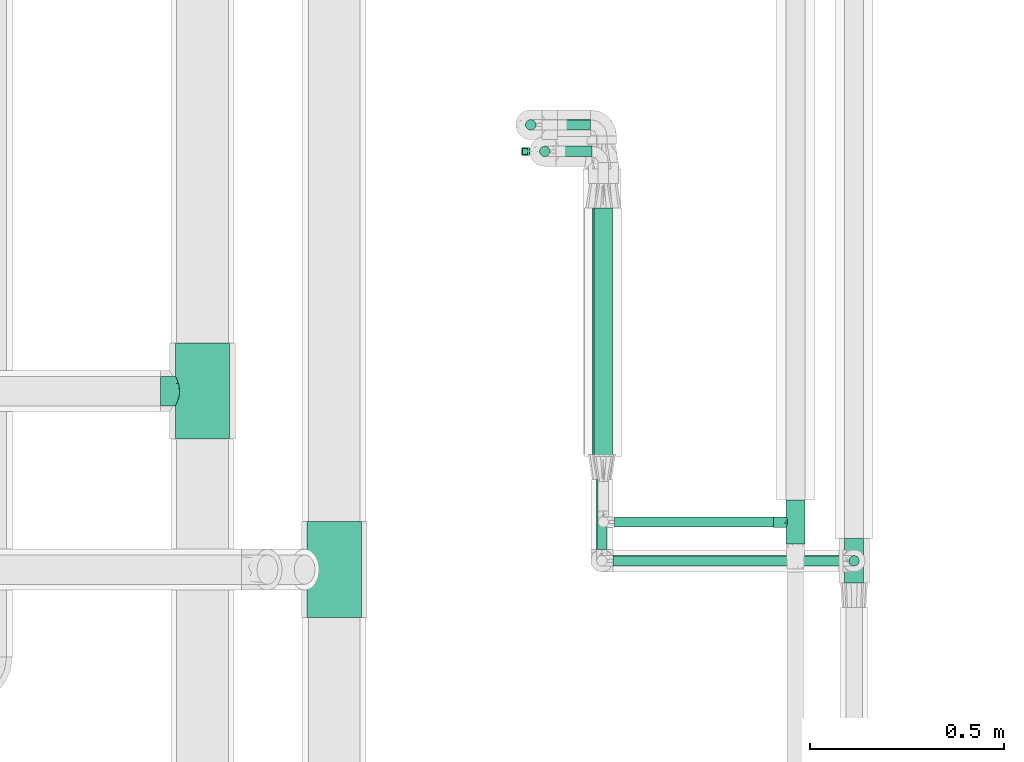
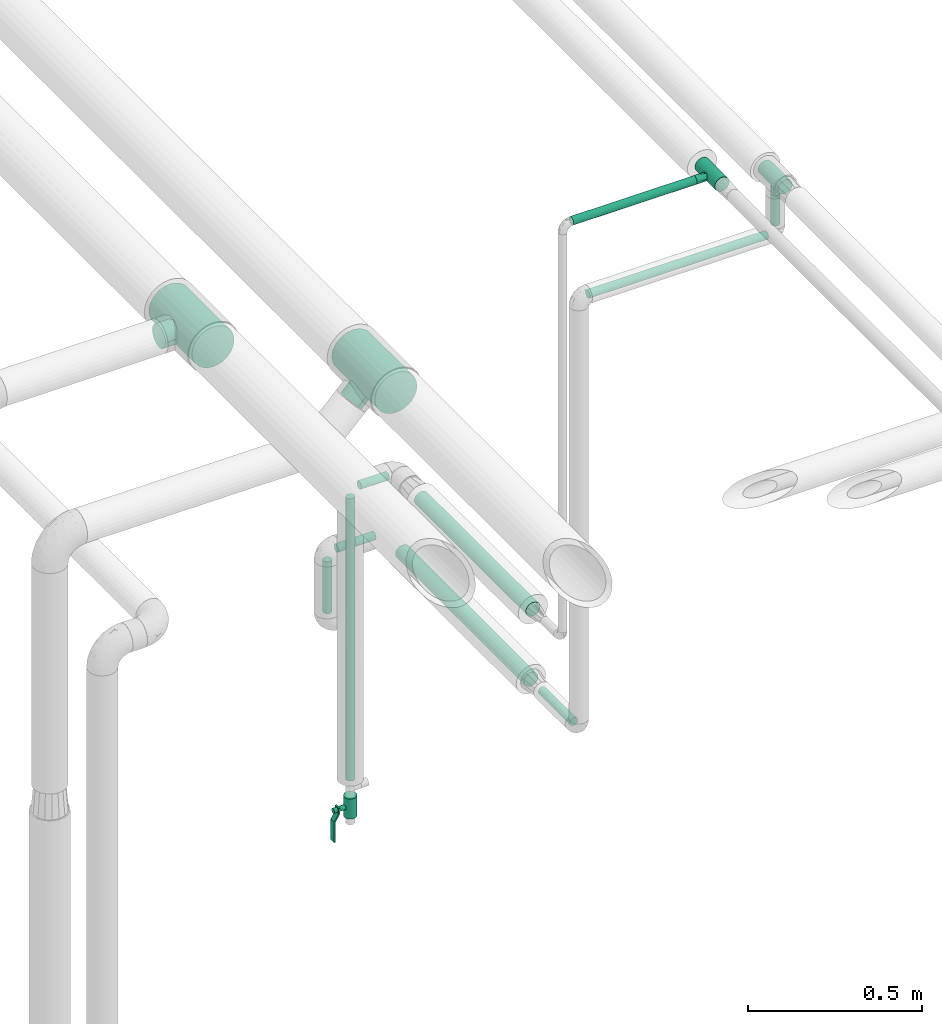
# One storey, part 555 of 827: 10 flow segments, 4 flow fittings, 1 flow controller.
"""IFC2X3 building model written with IfcOpenShell, lengths in millimetres."""

from ifc_helpers import new_model, entity, si_unit, converted_unit, derived_unit, direction, frame, origin, origin_2d_with_axis, place, context, subcontext, project, spatial, polyline, circle, outline, extrude, faceted_brep, source, transform, mapped, material, material_list, type_object, type_shapes, element, save


model = new_model("IFC2X3")

# Units and contexts
model_context = context("Model", 3, precision=0.01, world=origin(), true_north=direction((6.12303176911189e-17, 1.0)))
body_context = subcontext(model_context, "Body", "Model", "MODEL_VIEW")
ifc_project = project(units=[si_unit("LENGTHUNIT", "METRE", prefix="MILLI"), si_unit("AREAUNIT", "SQUARE_METRE"), si_unit("VOLUMEUNIT", "CUBIC_METRE"), converted_unit("PLANEANGLEUNIT", "DEGREE", entity("IfcRatioMeasure", 0.0174532925199433), si_unit("PLANEANGLEUNIT", "RADIAN"), dimensions=[0, 0, 0, 0, 0, 0, 0]), si_unit("MASSUNIT", "GRAM", prefix="KILO"), derived_unit("MASSDENSITYUNIT", [(si_unit("MASSUNIT", "GRAM", prefix="KILO"), 1), (si_unit("LENGTHUNIT", "METRE"), -3)]), derived_unit("MOMENTOFINERTIAUNIT", [(si_unit("LENGTHUNIT", "METRE"), 4)]), si_unit("TIMEUNIT", "SECOND"), si_unit("FREQUENCYUNIT", "HERTZ"), si_unit("THERMODYNAMICTEMPERATUREUNIT", "DEGREE_CELSIUS"), derived_unit("THERMALTRANSMITTANCEUNIT", [(si_unit("MASSUNIT", "GRAM", prefix="KILO"), 1), (si_unit("THERMODYNAMICTEMPERATUREUNIT", "KELVIN"), -1), (si_unit("TIMEUNIT", "SECOND"), -3)]), derived_unit("VOLUMETRICFLOWRATEUNIT", [(si_unit("LENGTHUNIT", "METRE"), 3), (si_unit("TIMEUNIT", "SECOND"), -1)]), derived_unit("MASSFLOWRATEUNIT", [(si_unit("MASSUNIT", "GRAM", prefix="KILO"), 1), (si_unit("TIMEUNIT", "SECOND"), -1)]), derived_unit("ROTATIONALFREQUENCYUNIT", [(si_unit("TIMEUNIT", "SECOND"), -1)]), si_unit("ELECTRICCURRENTUNIT", "AMPERE"), si_unit("ELECTRICVOLTAGEUNIT", "VOLT"), si_unit("POWERUNIT", "WATT"), si_unit("FORCEUNIT", "NEWTON", prefix="KILO"), si_unit("ILLUMINANCEUNIT", "LUX"), si_unit("LUMINOUSFLUXUNIT", "LUMEN"), si_unit("LUMINOUSINTENSITYUNIT", "CANDELA"), derived_unit("USERDEFINED", [(si_unit("MASSUNIT", "GRAM", prefix="KILO"), -1), (si_unit("LENGTHUNIT", "METRE"), -2), (si_unit("TIMEUNIT", "SECOND"), 3), (si_unit("LUMINOUSFLUXUNIT", "LUMEN"), 1)]), derived_unit("LINEARVELOCITYUNIT", [(si_unit("LENGTHUNIT", "METRE"), 1), (si_unit("TIMEUNIT", "SECOND"), -1)]), si_unit("PRESSUREUNIT", "PASCAL"), derived_unit("USERDEFINED", [(si_unit("LENGTHUNIT", "METRE"), -2), (si_unit("MASSUNIT", "GRAM", prefix="KILO"), 1), (si_unit("TIMEUNIT", "SECOND"), -2)]), derived_unit("LINEARFORCEUNIT", [(si_unit("MASSUNIT", "GRAM", prefix="KILO"), 1), (si_unit("LENGTHUNIT", "METRE"), 1), (si_unit("TIMEUNIT", "SECOND"), -2), (si_unit("LENGTHUNIT", "METRE"), -1)]), derived_unit("PLANARFORCEUNIT", [(si_unit("MASSUNIT", "GRAM", prefix="KILO"), 1), (si_unit("LENGTHUNIT", "METRE"), 1), (si_unit("TIMEUNIT", "SECOND"), -2), (si_unit("LENGTHUNIT", "METRE"), -2)])], contexts=[model_context])

# Site, building, storey
site_placement = place(None, origin())
site = spatial("IfcSite", under=ifc_project, at=site_placement, CompositionType="ELEMENT")
building_placement = place(site_placement, origin())
building = spatial("IfcBuilding", under=site, at=building_placement, CompositionType="ELEMENT")
storey_placement = place(building_placement, frame((0.0, 0.0, 28200.0)))
storey = spatial("IfcBuildingStorey", under=building, at=storey_placement, Name="08", CompositionType="ELEMENT", Elevation=28200.0)

# Flow segments
pipe_segment_type = type_object("IfcPipeSegmentType", PredefinedType="NOTDEFINED")
flow_segment_1_placement = place(storey_placement, frame((22897.4, 10907.28, 2983.13)))
element("IfcFlowSegment", 1, at=flow_segment_1_placement, inside=storey, type_object=pipe_segment_type, context=body_context, shape_type="SweptSolid", body=[
    extrude(circle(Radius=13.4, at=origin_2d_with_axis()), frame((0.0, 15.0, 15.0), z_axis=(1.0, 0.0, 0.0), x_axis=(0.0, 1.0, 0.0)), (0.0, 0.0, 1.0), 408.914810227833),
])
flow_segment_2_placement = place(storey_placement, frame((22893.47, 10807.39, 2789.32)))
element("IfcFlowSegment", 2, at=flow_segment_2_placement, inside=storey, type_object=pipe_segment_type, context=body_context, shape_type="SweptSolid", body=[
    extrude(circle(Radius=13.4, at=origin_2d_with_axis()), frame((0.0, 15.0, 15.0), z_axis=(1.0, 0.0, 0.0), x_axis=(0.0, 1.0, 0.0)), (0.0, 0.0, 1.0), 591.800000000013),
])
flow_segment_3_placement = place(storey_placement, frame((22849.37, 10851.49, 1285.57)))
element("IfcFlowSegment", 3, at=flow_segment_3_placement, inside=storey, type_object=pipe_segment_type, context=body_context, shape_type="SweptSolid", body=[
    extrude(circle(Radius=13.4, at=origin_2d_with_axis()), frame((15.0, 0.0, 15.0), z_axis=(0.0, 1.0, 0.0), x_axis=(1.0, 0.0, 0.0)), (0.0, 0.0, 1.0), 180.900000000015),
])
flow_segment_4_placement = place(storey_placement, frame((22666.07, 11931.0, 1087.42)))
element("IfcFlowSegment", 4, at=flow_segment_4_placement, inside=storey, type_object=pipe_segment_type, context=body_context, shape_type="SweptSolid", body=[
    extrude(circle(Radius=13.4, at=origin_2d_with_axis()), frame((15.0, 15.0, 0.0), z_axis=(0.0, 0.0, 1.0), x_axis=(-1.0, 0.0, 0.0)), (0.0, 0.0, 1.0), 181.800000000011),
])
flow_segment_5_placement = place(storey_placement, frame((22710.17, 11931.0, 1283.32)))
element("IfcFlowSegment", 5, at=flow_segment_5_placement, inside=storey, type_object=pipe_segment_type, context=body_context, shape_type="SweptSolid", body=[
    extrude(circle(Radius=13.4, at=origin_2d_with_axis()), frame((0.0, 15.0, 15.0), z_axis=(1.0, 0.0, 0.0), x_axis=(0.0, -1.0, 0.0)), (0.0, 0.0, 1.0), 125.102915885275),
])
flow_segment_6_placement = place(storey_placement, frame((22746.42, 11862.51, 1532.66)))
element("IfcFlowSegment", 6, at=flow_segment_6_placement, inside=storey, type_object=pipe_segment_type, context=body_context, shape_type="SweptSolid", body=[
    extrude(circle(Radius=13.4, at=origin_2d_with_axis()), frame((0.0, 15.0, 15.0), z_axis=(1.0, -1.1199062174231e-05, 0.0), x_axis=(-1.1199062174231e-05, -1.0, 0.0)), (0.0, 0.0, 1.0), 92.7817921332766),
])
flow_segment_7_placement = place(storey_placement, frame((22702.32, 11862.51, 530.81)))
element("IfcFlowSegment", 7, at=flow_segment_7_placement, inside=storey, type_object=pipe_segment_type, context=body_context, shape_type="SweptSolid", body=[
    extrude(circle(Radius=13.4, at=origin_2d_with_axis()), frame((15.0, 15.0, 0.0)), (0.0, 0.0, 1.0), 987.744160138895),
])
flow_segment_8_placement = place(storey_placement, frame((23499.37, 10807.39, 2833.42)))
element("IfcFlowSegment", 8, at=flow_segment_8_placement, inside=storey, type_object=pipe_segment_type, context=body_context, shape_type="SweptSolid", body=[
    extrude(circle(Radius=13.4, at=origin_2d_with_axis()), frame((15.0, 15.0, 0.0), z_axis=(0.000144374111164791, 0.0, 0.999999989578058), x_axis=(-0.999999989578058, 0.0, 0.000144374111164791)), (0.0, 0.0, 1.0), 106.060680821969),
])
flow_segment_9_placement = place(storey_placement, frame((22842.7, 11091.27, 1521.8)))
element("IfcFlowSegment", 9, at=flow_segment_9_placement, inside=storey, type_object=pipe_segment_type, context=body_context, shape_type="SweptSolid", body=[
    extrude(circle(Radius=24.0, at=origin_2d_with_axis()), frame((25.6, 0.0, 25.6), z_axis=(0.0, 1.0, 0.0), x_axis=(1.0, 0.0, 0.0)), (0.0, 0.0, 1.0), 640.000234291941),
])
flow_segment_10_placement = place(storey_placement, frame((22838.77, 11096.39, 1274.97)))
element("IfcFlowSegment", 10, at=flow_segment_10_placement, inside=storey, type_object=pipe_segment_type, context=body_context, shape_type="SweptSolid", body=[
    extrude(circle(Radius=24.0, at=origin_2d_with_axis()), frame((25.6, 0.0, 25.6), z_axis=(0.0, 1.0, 0.0), x_axis=(1.0, 0.0, 0.0)), (0.0, 0.0, 1.0), 735.999999999999),
])

# Flow controller
ifc_material = material()
ifc_material_list = material_list([ifc_material, ifc_material, ifc_material, ifc_material, ifc_material])
valve_type = type_object("IfcValveType", PredefinedType="NOTDEFINED", material=ifc_material_list)
shared_shape_1 = source(origin(), body_context, "Body", "SweptSolid", [
    extrude(circle(Radius=20.0, at=origin_2d_with_axis()), frame((-35.0, 0.0, 0.0), z_axis=(1.0, 0.0, 0.0), x_axis=(0.0, 1.0, 0.0)), (0.0, 0.0, 1.0), 23.3333333333333),
    extrude(circle(Radius=20.0, at=origin_2d_with_axis()), frame((-11.67, 0.0, 0.0), z_axis=(1.0, 0.0, 0.0), x_axis=(0.0, 1.0, 0.0)), (0.0, 0.0, 1.0), 23.3333333333333),
    extrude(circle(Radius=20.0, at=origin_2d_with_axis()), frame((11.67, 0.0, 0.0), z_axis=(1.0, 0.0, 0.0), x_axis=(0.0, 1.0, 0.0)), (0.0, 0.0, 1.0), 23.3333333333333),
    extrude(outline(polyline([(-44.88, -5.0), (-44.88, -10.0), (-24.17, -10.0), (0.33, 5.0), (70.12, 5.0), (70.12, 10.0), (-1.08, 10.0), (-25.58, -5.0), (-44.88, -5.0)])), frame((34.88, -10.0, 49.5), z_axis=(0.0, -1.0, 0.0), x_axis=(1.0, 0.0, 0.0)), (0.0, 0.0, -1.0), 20.0),
    extrude(circle(Radius=8.0, at=origin_2d_with_axis()), origin(), (0.0, 0.0, 1.0), 57.0),
])
type_shapes(valve_type, [shared_shape_1])
flow_controller_placement = place(storey_placement, frame((22717.32, 11877.51, 437.81), z_axis=(-1.0, 0.0, 0.0), x_axis=(0.0, 2.2257853542038e-06, -1.0)))
element("IfcFlowController", 11, at=flow_controller_placement, inside=storey, type_object=valve_type, material=ifc_material_list, context=body_context, shape_type="MappedRepresentation", body=[
    mapped(shared_shape_1, transform((0.0, 0.0, 0.0), scale=1.0)),
])

# Flow fittings
pipe_fitting_type_1 = type_object("IfcPipeFittingType", Name="ADSK_1", PredefinedType="NOTDEFINED", material=ifc_material)
shared_shape_2 = source(origin(), body_context, "Body", "Brep", [
    faceted_brep([(-57.0, 12.07, -20.91), (-57.0, 6.25, -23.33), (-57.0, 0.0, -24.15), (-57.0, -6.25, -23.33), (-57.0, -12.08, -20.91), (-57.0, -17.08, -17.08), (-57.0, -20.91, -12.08), (-57.0, -23.33, -6.25), (-57.0, -24.15, 0.0), (-57.0, -23.33, 6.25), (-57.0, -20.91, 12.07), (-57.0, -17.08, 17.08), (-57.0, -12.08, 20.91), (-57.0, -6.25, 23.33), (-57.0, 0.0, 24.15), (-57.0, 6.25, 23.33), (-57.0, 12.07, 20.91), (-57.0, 17.08, 17.08), (-57.0, 20.91, 12.07), (-57.0, 23.33, 6.25), (-57.0, 24.15, 0.0), (-57.0, 23.33, -6.25), (-57.0, 20.91, -12.08), (-57.0, 17.08, -17.08), (57.0, 0.0, -24.15), (57.0, 6.25, -23.33), (57.0, 12.07, -20.91), (57.0, 17.08, -17.08), (57.0, 20.91, -12.08), (57.0, 23.33, -6.25), (57.0, 24.15, 0.0), (57.0, 23.33, 6.25), (57.0, 20.91, 12.07), (57.0, 17.08, 17.08), (57.0, 12.07, 20.91), (57.0, 6.25, 23.33), (57.0, 0.0, 24.15), (57.0, -6.25, 23.33), (57.0, -12.08, 20.91), (57.0, -17.08, 17.08), (57.0, -20.91, 12.07), (57.0, -23.33, 6.25), (57.0, -24.15, 0.0), (57.0, -23.33, -6.25), (57.0, -20.91, -12.08), (57.0, -17.08, -17.08), (57.0, -12.08, -20.91), (57.0, -6.25, -23.33), (12.61, -23.69, 4.67), (13.03, -23.92, 2.34), (13.45, -24.15, 0.0), (10.28, -22.54, 8.68), (2.38, -20.2, 13.24), (6.77, -21.17, 11.62), (4.58, -20.68, 12.43), (-13.45, -24.15, 0.0), (-13.03, -23.92, 2.34), (-12.61, -23.69, 4.67), (-10.28, -22.54, 8.67), (-6.77, -21.17, 11.62), (-4.58, -20.68, 12.43), (-2.38, -20.2, 13.24), (0.0, -20.2, 13.24), (2.38, -20.2, -13.24), (6.77, -21.17, -11.62), (4.58, -20.68, -12.43), (10.28, -22.54, -8.68), (12.61, -23.69, -4.67), (13.03, -23.92, -2.34), (-2.38, -20.2, -13.24), (-4.58, -20.68, -12.43), (-6.77, -21.17, -11.62), (-10.28, -22.54, -8.67), (0.0, -20.2, -13.24), (-12.61, -23.69, -4.67), (-13.03, -23.92, -2.34), (-12.99, -57.0, -3.48), (-11.65, -57.0, -6.73), (-9.51, -57.0, -9.51), (-6.72, -57.0, -11.65), (-3.48, -57.0, -12.99), (0.0, -57.0, -13.45), (3.48, -57.0, -12.99), (6.73, -57.0, -11.65), (9.51, -57.0, -9.51), (11.65, -57.0, -6.73), (12.99, -57.0, -3.48), (13.45, -57.0, 0.0), (12.99, -57.0, 3.48), (11.65, -57.0, 6.72), (9.51, -57.0, 9.51), (6.73, -57.0, 11.65), (3.48, -57.0, 12.99), (0.0, -57.0, 13.45), (-3.48, -57.0, 12.99), (-6.72, -57.0, 11.65), (-9.51, -57.0, 9.51), (-11.65, -57.0, 6.72), (-12.99, -57.0, 3.48), (-13.45, -57.0, 0.0)], [[[0, 1, 2, 3, 4, 5, 6, 7, 8, 9, 10, 11, 12, 13, 14, 15, 16, 17, 18, 19, 20, 21, 22, 23]], [[24, 25, 26, 27, 28, 29, 30, 31, 32, 33, 34, 35, 36, 37, 38, 39, 40, 41, 42, 43, 44, 45, 46, 47]], [[42, 41, 48]], [[42, 48, 49, 50]], [[41, 51, 48]], [[40, 39, 52]], [[53, 51, 40]], [[40, 52, 54, 53]], [[39, 11, 52]], [[40, 51, 41]], [[8, 55, 56, 57]], [[9, 8, 57]], [[57, 58, 9]], [[10, 59, 60, 61]], [[59, 10, 58]], [[10, 61, 11]], [[58, 10, 9]], [[11, 61, 62, 52]], [[39, 38, 12, 11]], [[14, 13, 37, 36]], [[13, 12, 38, 37]], [[15, 14, 36, 35]], [[32, 31, 19, 18]], [[17, 16, 34, 33]], [[18, 17, 33, 32]], [[35, 34, 16, 15]], [[20, 19, 31, 30]], [[29, 28, 22, 21]], [[28, 27, 23, 22]], [[30, 29, 21, 20]], [[24, 47, 3, 2]], [[1, 0, 26, 25]], [[2, 1, 25, 24]], [[27, 26, 0, 23]], [[4, 3, 47, 46]], [[46, 45, 5, 4]], [[45, 44, 63]], [[44, 64, 65, 63]], [[44, 66, 64]], [[45, 63, 5]], [[43, 42, 67]], [[67, 66, 43]], [[42, 50, 68, 67]], [[43, 66, 44]], [[6, 69, 70, 71]], [[6, 5, 69]], [[71, 72, 6]], [[5, 63, 73, 69]], [[72, 74, 7]], [[74, 8, 7]], [[8, 74, 75, 55]], [[72, 7, 6]], [[76, 77, 78, 79, 80, 81, 82, 83, 84, 85, 86, 87, 88, 89, 90, 91, 92, 93, 94, 95, 96, 97, 98, 99]], [[57, 98, 97]], [[59, 96, 95]], [[97, 96, 58]], [[91, 54, 92]], [[56, 99, 98]], [[55, 99, 56]], [[98, 57, 56]], [[58, 57, 97]], [[96, 59, 58]], [[49, 48, 88]], [[60, 59, 95]], [[94, 61, 60]], [[49, 87, 50]], [[93, 52, 62, 61]], [[91, 53, 54]], [[90, 53, 91]], [[48, 89, 88]], [[90, 89, 51]], [[52, 93, 92]], [[54, 52, 92]], [[60, 95, 94]], [[53, 90, 51]], [[51, 89, 48]], [[93, 61, 94]], [[87, 49, 88]], [[86, 68, 87]], [[81, 63, 82]], [[65, 83, 82]], [[65, 64, 83]], [[86, 67, 68]], [[67, 86, 85]], [[75, 74, 76]], [[66, 85, 84]], [[68, 50, 87]], [[67, 85, 66]], [[79, 70, 80]], [[64, 66, 84]], [[82, 63, 65]], [[64, 84, 83]], [[81, 69, 73, 63]], [[79, 71, 70]], [[78, 71, 79]], [[74, 77, 76]], [[78, 77, 72]], [[69, 81, 80]], [[70, 69, 80]], [[71, 78, 72]], [[72, 77, 74]], [[99, 75, 76]], [[75, 99, 55]]]),
])
type_shapes(pipe_fitting_type_1, [shared_shape_2])
for number, where, z_axis, x_axis, name in (
    (12, (23363.31, 10922.27, 2998.12), (0.0, 0.0, 1.0), (0.0, -1.0, 0.0), "ADSK_1"),
    (13, (23514.38, 10822.39, 2996.48), (-1.0, 0.0, 0.0), (0.0, -1.0, 0.0), "ADSK_1"),
):
    element("IfcFlowFitting", number, at=place(storey_placement, frame(where, z_axis=z_axis, x_axis=x_axis)), inside=storey, type_object=pipe_fitting_type_1, material=ifc_material, Name=name, ObjectType="ADSK_1", context=body_context, shape_type="MappedRepresentation", body=[
        mapped(shared_shape_2, transform((0.0, 0.0, 0.0), scale=1.0)),
    ])
pipe_fitting_type_2 = type_object("IfcPipeFittingType", Name="ADSK_1", PredefinedType="NOTDEFINED", material=ifc_material)
shared_shape_3 = source(origin(), body_context, "Body", "Brep", [
    faceted_brep([(-124.0, 18.08, -67.47), (-124.0, 0.0, -69.85), (-124.0, -18.08, -67.47), (-124.0, -34.93, -60.49), (-124.0, -49.39, -49.39), (-124.0, -60.49, -34.93), (-124.0, -67.47, -18.08), (-124.0, -69.85, 0.0), (-124.0, -67.47, 18.08), (-124.0, -60.49, 34.92), (-124.0, -49.39, 49.39), (-124.0, -34.93, 60.49), (-124.0, -18.08, 67.47), (-124.0, 0.0, 69.85), (-124.0, 18.08, 67.47), (-124.0, 34.92, 60.49), (-124.0, 49.39, 49.39), (-124.0, 60.49, 34.92), (-124.0, 67.47, 18.08), (-124.0, 69.85, 0.0), (-124.0, 67.47, -18.08), (-124.0, 60.49, -34.93), (-124.0, 49.39, -49.39), (-124.0, 34.92, -60.49), (124.0, 49.39, -49.39), (124.0, 60.49, -34.93), (124.0, 67.47, -18.08), (124.0, 69.85, 0.0), (124.0, 67.47, 18.08), (124.0, 60.49, 34.92), (124.0, 49.39, 49.39), (124.0, 34.92, 60.49), (124.0, 18.08, 67.47), (124.0, 0.0, 69.85), (124.0, -18.08, 67.47), (124.0, -34.93, 60.49), (124.0, -49.39, 49.39), (124.0, -60.49, 34.92), (124.0, -67.47, 18.08), (124.0, -69.85, 0.0), (124.0, -67.47, -18.08), (124.0, -60.49, -34.93), (124.0, -49.39, -49.39), (124.0, -34.93, -60.49), (124.0, -18.08, -67.47), (124.0, 0.0, -69.85), (124.0, 18.08, -67.47), (124.0, 34.92, -60.49), (35.68, -68.59, 13.21), (36.87, -69.22, 6.61), (38.05, -69.85, 0.0), (29.07, -65.39, 24.55), (6.73, -58.96, 37.45), (19.15, -61.63, 32.88), (12.94, -60.29, 35.16), (-38.05, -69.85, 0.0), (-36.87, -69.22, 6.61), (-35.68, -68.59, 13.21), (-29.08, -65.4, 24.54), (-19.15, -61.63, 32.88), (-12.95, -60.3, 35.16), (-6.74, -58.96, 37.45), (-0.01, -58.96, 37.45), (6.73, -58.96, -37.45), (19.15, -61.63, -32.88), (12.94, -60.29, -35.16), (29.07, -65.39, -24.55), (35.68, -68.59, -13.21), (36.87, -69.22, -6.61), (-6.74, -58.96, -37.45), (-12.95, -60.3, -35.16), (-19.15, -61.63, -32.88), (-29.08, -65.4, -24.54), (-0.01, -58.96, -37.45), (-35.68, -68.59, -13.21), (-36.87, -69.22, -6.61), (9.85, -108.0, -36.75), (19.03, -108.0, -32.95), (26.91, -108.0, -26.91), (32.95, -108.0, -19.03), (36.75, -108.0, -9.85), (38.05, -108.0, 0.0), (36.75, -108.0, 9.85), (32.95, -108.0, 19.02), (26.91, -108.0, 26.91), (19.03, -108.0, 32.95), (9.85, -108.0, 36.75), (0.0, -108.0, 38.05), (-9.85, -108.0, 36.75), (-19.02, -108.0, 32.95), (-26.91, -108.0, 26.91), (-32.95, -108.0, 19.02), (-36.75, -108.0, 9.85), (-38.05, -108.0, 0.0), (-36.75, -108.0, -9.85), (-32.95, -108.0, -19.03), (-26.91, -108.0, -26.91), (-19.02, -108.0, -32.95), (-9.85, -108.0, -36.75), (0.0, -108.0, -38.05)], [[[0, 1, 2, 3, 4, 5, 6, 7, 8, 9, 10, 11, 12, 13, 14, 15, 16, 17, 18, 19, 20, 21, 22, 23]], [[24, 25, 26, 27, 28, 29, 30, 31, 32, 33, 34, 35, 36, 37, 38, 39, 40, 41, 42, 43, 44, 45, 46, 47]], [[39, 38, 48]], [[39, 48, 49, 50]], [[38, 51, 48]], [[37, 36, 52]], [[53, 51, 37]], [[37, 52, 54, 53]], [[36, 10, 52]], [[37, 51, 38]], [[7, 55, 56, 57]], [[8, 7, 57]], [[57, 58, 8]], [[9, 59, 60, 61]], [[59, 9, 58]], [[9, 61, 10]], [[58, 9, 8]], [[10, 61, 62, 52]], [[36, 35, 11, 10]], [[13, 12, 34, 33]], [[12, 11, 35, 34]], [[14, 13, 33, 32]], [[29, 28, 18, 17]], [[16, 15, 31, 30]], [[17, 16, 30, 29]], [[32, 31, 15, 14]], [[19, 18, 28, 27]], [[20, 26, 25, 21]], [[25, 24, 22, 21]], [[27, 26, 20, 19]], [[45, 44, 2, 1]], [[0, 23, 47, 46]], [[1, 0, 46, 45]], [[24, 47, 23, 22]], [[43, 3, 2, 44]], [[43, 42, 4, 3]], [[42, 41, 63]], [[41, 64, 65, 63]], [[41, 66, 64]], [[42, 63, 4]], [[40, 39, 67]], [[67, 66, 40]], [[39, 50, 68, 67]], [[40, 66, 41]], [[5, 69, 70, 71]], [[5, 4, 69]], [[71, 72, 5]], [[4, 63, 73, 69]], [[72, 74, 6]], [[74, 7, 6]], [[7, 74, 75, 55]], [[72, 6, 5]], [[76, 77, 78, 79, 80, 81, 82, 83, 84, 85, 86, 87, 88, 89, 90, 91, 92, 93, 94, 95, 96, 97, 98, 99]], [[56, 93, 92]], [[60, 89, 88]], [[59, 90, 89]], [[60, 59, 89]], [[87, 61, 88]], [[85, 54, 86]], [[92, 57, 56]], [[55, 93, 56]], [[57, 92, 91]], [[57, 91, 58]], [[49, 81, 50]], [[90, 58, 91]], [[90, 59, 58]], [[88, 61, 60]], [[87, 52, 62, 61]], [[85, 53, 54]], [[84, 53, 85]], [[48, 83, 82]], [[84, 83, 51]], [[52, 87, 86]], [[54, 52, 86]], [[49, 48, 82]], [[53, 84, 51]], [[51, 83, 48]], [[81, 49, 82]], [[80, 68, 81]], [[80, 67, 68]], [[65, 77, 76]], [[78, 66, 79]], [[80, 79, 67]], [[99, 63, 76]], [[64, 78, 77]], [[68, 50, 81]], [[67, 79, 66]], [[76, 63, 65]], [[64, 66, 78]], [[99, 69, 73, 63]], [[97, 70, 98]], [[75, 74, 94]], [[97, 71, 70]], [[75, 93, 55]], [[96, 71, 97]], [[74, 95, 94]], [[96, 95, 72]], [[69, 99, 98]], [[70, 69, 98]], [[71, 96, 72]], [[72, 95, 74]], [[93, 75, 94]], [[65, 64, 77]]]),
])
type_shapes(pipe_fitting_type_2, [shared_shape_3])
for number, where, z_axis, x_axis, name in (
    (14, (21835.11, 11259.65, 2800.0), (0.0, 0.0, 1.0), (0.0, -1.0, 0.0), "ADSK_1"),
    (15, (22174.76, 10799.65, 2799.93), (-0.707106781186547, 0.0, 0.707106781186548), (0.0, -1.0, 0.0), "ADSK_1"),
):
    element("IfcFlowFitting", number, at=place(storey_placement, frame(where, z_axis=z_axis, x_axis=x_axis)), inside=storey, type_object=pipe_fitting_type_2, material=ifc_material, Name=name, ObjectType="ADSK_1", context=body_context, shape_type="MappedRepresentation", body=[
        mapped(shared_shape_3, transform((0.0, 0.0, 0.0), scale=1.0)),
    ])

save(model, "model.ifc")
